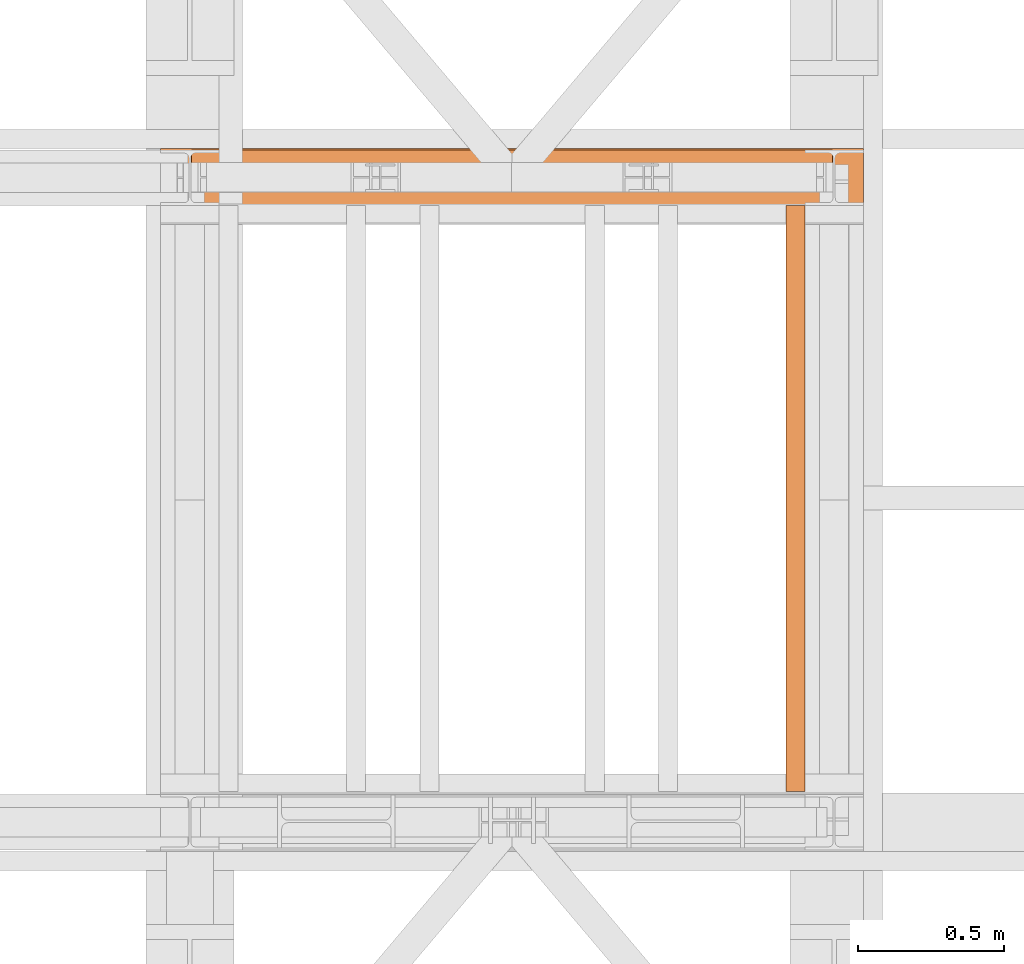
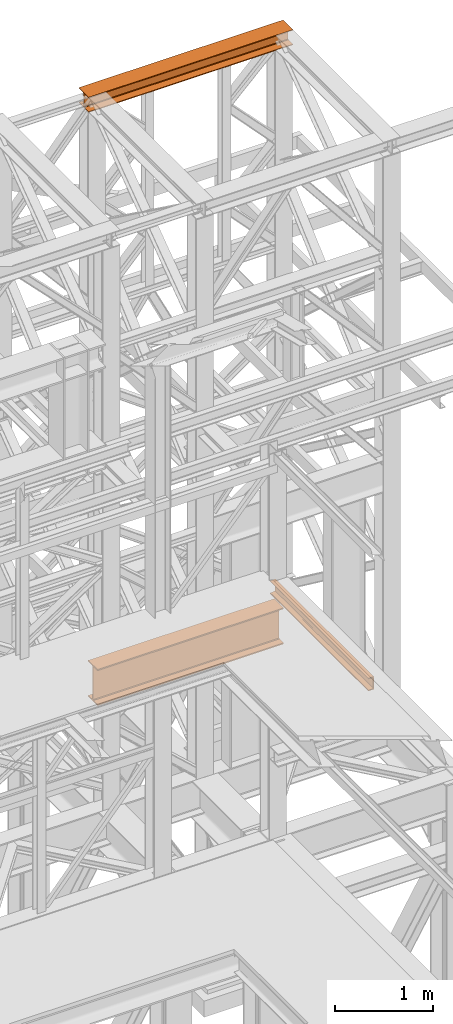
# One storey, part 186 of 208: 3 proxies.
"""IFC2X3 building model written with IfcOpenShell, lengths in millimetres."""

from ifc_helpers import new_model, entity, si_unit, converted_unit, frame, origin, origin_with_axes, place, context, subcontext, project, spatial, faceted_brep, element, save


model = new_model("IFC2X3")

# Units and contexts
model_context = context("Model", 3, precision=1e-05, world=origin())
plan_context = context("Plan", 3, precision=1e-05, world=origin())
body_context = subcontext(model_context, "Body", "Model", "MODEL_VIEW")
ifc_project = project(units=[si_unit("LENGTHUNIT", "METRE", prefix="MILLI"), converted_unit("PLANEANGLEUNIT", "DEGREE", entity("IfcPlaneAngleMeasure", 0.0174532925199433), si_unit("PLANEANGLEUNIT", "RADIAN"), dimensions=[0, 0, 0, 0, 0, 0, 0]), si_unit("AREAUNIT", "SQUARE_METRE"), si_unit("VOLUMEUNIT", "CUBIC_METRE")], contexts=[model_context, plan_context])

# Building, storey
building_placement = place(None, origin())
building = spatial("IfcBuilding", under=ifc_project, at=building_placement, CompositionType="COMPLEX")
storey_placement = place(building_placement, origin_with_axes())
storey = spatial("IfcBuildingStorey", under=building, at=storey_placement, Name="Geschoss", CompositionType="ELEMENT")

# Proxies
proxy_1_placement = place(storey_placement, frame((6599.254968580832, -13857.57439657637, 4834.989987483023), z_axis=(0.0, 0.0, 1.0), x_axis=(1.0, 0.0, 0.0)))
element("IfcBuildingElementProxy", 1, at=proxy_1_placement, inside=storey, context=body_context, shape_type="Brep", body=[
    faceted_brep([(2188.009999895692, 0.01000000000021828, 450.0100178813937), (2188.009999895692, 190.0100125169756, 450.0100178813937), (2188.009999895692, 190.0100125169756, 435.4100240564349), (2188.009999895692, 120.7100073045494, 435.4100091552737), (2188.009999895692, 109.841562265754, 433.2347078418734), (2188.009999895692, 101.8853126263621, 425.2784563398363), (2188.009999895692, 99.71000619068764, 414.4100113010409), (2188.009999895692, 99.71000619068764, 35.60999167919181), (2188.009999895692, 101.8853126263621, 24.74154664039634), (2188.009999895692, 109.841562265754, 16.78529513835929), (2188.009999895692, 120.7100073045494, 14.60999382495902), (2188.009999895692, 190.0100125169756, 14.60999382495902), (2188.009999895692, 190.0100125169756, 0.01000000000021828), (2188.009999895692, 0.01000000000021828, 0.01000000000021828), (2188.009999895692, 0.01000000000021828, 14.60999382495902), (2188.009999895692, 69.3100052124264, 14.60999382495902), (2188.009999895692, 80.17845025122188, 16.78529513835929), (2188.009999895692, 88.13469989061377, 24.74154664039634), (2188.009999895692, 90.3100063262882, 35.60999167919181), (2188.009999895692, 90.3100063262882, 414.4100113010409), (2188.009999895692, 88.13469989061377, 425.2784563398363), (2188.009999895692, 80.17845025122188, 433.2347078418734), (2188.009999895692, 69.3100052124264, 435.4100091552737), (2188.009999895692, 0.01000000000021828, 435.4100240564349), (2188.009999895692, 190.0100125169756, 450.0100178813937), (2188.009999895692, 0.01000000000021828, 450.0100178813937), (0.01000000000021828, 0.01000000000021828, 450.0100178813937), (0.01000000000021828, 190.0100125169756, 450.0100178813937), (2188.009999895692, 190.0100125169756, 435.4100240564349), (2188.009999895692, 190.0100125169756, 450.0100178813937), (0.01000000000021828, 190.0100125169756, 450.0100178813937), (0.01000000000021828, 190.0100125169756, 435.4100240564349), (2188.009999895692, 120.7100073045494, 435.4100091552737), (2188.009999895692, 190.0100125169756, 435.4100240564349), (0.01000000000021828, 190.0100125169756, 435.4100240564349), (0.01000000000021828, 120.7100073045494, 435.4100091552737), (2188.009999895692, 109.841562265754, 433.2347078418734), (2188.009999895692, 120.7100073045494, 435.4100091552737), (0.01000000000021828, 120.7100073045494, 435.4100091552737), (0.01000000000021828, 109.841562265754, 433.2347078418734), (2188.009999895692, 101.8853126263621, 425.2784563398363), (2188.009999895692, 109.841562265754, 433.2347078418734), (0.01000000000021828, 109.841562265754, 433.2347078418734), (0.01000000000021828, 101.8853126263621, 425.2784563398363), (2188.009999895692, 99.71000619068764, 414.4100113010409), (2188.009999895692, 101.8853126263621, 425.2784563398363), (0.01000000000021828, 101.8853126263621, 425.2784563398363), (0.01000000000021828, 99.71000619068764, 414.4100113010409), (2188.009999895692, 99.71000619068764, 35.60999167919181), (2188.009999895692, 99.71000619068764, 414.4100113010409), (0.01000000000021828, 99.71000619068764, 414.4100113010409), (0.01000000000021828, 99.71000619068764, 35.60999167919181), (2188.009999895692, 101.8853126263621, 24.74154664039634), (2188.009999895692, 99.71000619068764, 35.60999167919181), (0.01000000000021828, 99.71000619068764, 35.60999167919181), (0.01000000000021828, 101.8853126263621, 24.74154664039634), (2188.009999895692, 109.841562265754, 16.78529513835929), (2188.009999895692, 101.8853126263621, 24.74154664039634), (0.01000000000021828, 101.8853126263621, 24.74154664039634), (0.01000000000021828, 109.841562265754, 16.78529513835929), (2188.009999895692, 120.7100073045494, 14.60999382495902), (2188.009999895692, 109.841562265754, 16.78529513835929), (0.01000000000021828, 109.841562265754, 16.78529513835929), (0.01000000000021828, 120.7100073045494, 14.60999382495902), (2188.009999895692, 190.0100125169756, 14.60999382495902), (2188.009999895692, 120.7100073045494, 14.60999382495902), (0.01000000000021828, 120.7100073045494, 14.60999382495902), (0.01000000000021828, 190.0100125169756, 14.60999382495902), (2188.009999895692, 190.0100125169756, 0.01000000000021828), (2188.009999895692, 190.0100125169756, 14.60999382495902), (0.01000000000021828, 190.0100125169756, 14.60999382495902), (0.01000000000021828, 190.0100125169756, 0.01000000000021828), (2188.009999895692, 0.01000000000021828, 0.01000000000021828), (2188.009999895692, 190.0100125169756, 0.01000000000021828), (0.01000000000021828, 190.0100125169756, 0.01000000000021828), (0.01000000000021828, 0.01000000000021828, 0.01000000000021828), (2188.009999895692, 0.01000000000021828, 14.60999382495902), (2188.009999895692, 0.01000000000021828, 0.01000000000021828), (0.01000000000021828, 0.01000000000021828, 0.01000000000021828), (0.01000000000021828, 0.01000000000021828, 14.60999382495902), (2188.009999895692, 69.3100052124264, 14.60999382495902), (2188.009999895692, 0.01000000000021828, 14.60999382495902), (0.01000000000021828, 0.01000000000021828, 14.60999382495902), (0.01000000000021828, 69.3100052124264, 14.60999382495902), (2188.009999895692, 80.17845025122188, 16.78529513835929), (2188.009999895692, 69.3100052124264, 14.60999382495902), (0.01000000000021828, 69.3100052124264, 14.60999382495902), (0.01000000000021828, 80.17845025122188, 16.78529513835929), (2188.009999895692, 88.13469989061377, 24.74154664039634), (2188.009999895692, 80.17845025122188, 16.78529513835929), (0.01000000000021828, 80.17845025122188, 16.78529513835929), (0.01000000000021828, 88.13469989061377, 24.74154664039634), (2188.009999895692, 90.3100063262882, 35.60999167919181), (2188.009999895692, 88.13469989061377, 24.74154664039634), (0.01000000000021828, 88.13469989061377, 24.74154664039634), (0.01000000000021828, 90.3100063262882, 35.60999167919181), (2188.009999895692, 90.3100063262882, 414.4100113010409), (2188.009999895692, 90.3100063262882, 35.60999167919181), (0.01000000000021828, 90.3100063262882, 35.60999167919181), (0.01000000000021828, 90.3100063262882, 414.4100113010409), (2188.009999895692, 88.13469989061377, 425.2784563398363), (2188.009999895692, 90.3100063262882, 414.4100113010409), (0.01000000000021828, 90.3100063262882, 414.4100113010409), (0.01000000000021828, 88.13469989061377, 425.2784563398363), (2188.009999895692, 80.17845025122188, 433.2347078418734), (2188.009999895692, 88.13469989061377, 425.2784563398363), (0.01000000000021828, 88.13469989061377, 425.2784563398363), (0.01000000000021828, 80.17845025122188, 433.2347078418734), (2188.009999895692, 69.3100052124264, 435.4100091552737), (2188.009999895692, 80.17845025122188, 433.2347078418734), (0.01000000000021828, 80.17845025122188, 433.2347078418734), (0.01000000000021828, 69.3100052124264, 435.4100091552737), (2188.009999895692, 0.01000000000021828, 435.4100240564349), (2188.009999895692, 69.3100052124264, 435.4100091552737), (0.01000000000021828, 69.3100052124264, 435.4100091552737), (0.01000000000021828, 0.01000000000021828, 435.4100240564349), (2188.009999895692, 0.01000000000021828, 450.0100178813937), (2188.009999895692, 0.01000000000021828, 435.4100240564349), (0.01000000000021828, 0.01000000000021828, 435.4100240564349), (0.01000000000021828, 0.01000000000021828, 450.0100178813937), (0.01000000000021828, 0.01000000000021828, 450.0100178813937), (0.01000000000021828, 0.01000000000021828, 435.4100240564349), (0.01000000000021828, 69.3100052124264, 435.4100091552737), (0.01000000000021828, 80.17845025122188, 433.2347078418734), (0.01000000000021828, 88.13469989061377, 425.2784563398363), (0.01000000000021828, 90.3100063262882, 414.4100113010409), (0.01000000000021828, 90.3100063262882, 35.60999167919181), (0.01000000000021828, 88.13469989061377, 24.74154664039634), (0.01000000000021828, 80.17845025122188, 16.78529513835929), (0.01000000000021828, 69.3100052124264, 14.60999382495902), (0.01000000000021828, 0.01000000000021828, 14.60999382495902), (0.01000000000021828, 0.01000000000021828, 0.01000000000021828), (0.01000000000021828, 190.0100125169756, 0.01000000000021828), (0.01000000000021828, 190.0100125169756, 14.60999382495902), (0.01000000000021828, 120.7100073045494, 14.60999382495902), (0.01000000000021828, 109.841562265754, 16.78529513835929), (0.01000000000021828, 101.8853126263621, 24.74154664039634), (0.01000000000021828, 99.71000619068764, 35.60999167919181), (0.01000000000021828, 99.71000619068764, 414.4100113010409), (0.01000000000021828, 101.8853126263621, 425.2784563398363), (0.01000000000021828, 109.841562265754, 433.2347078418734), (0.01000000000021828, 120.7100073045494, 435.4100091552737), (0.01000000000021828, 190.0100125169756, 435.4100240564349), (0.01000000000021828, 190.0100125169756, 450.0100178813937)], [[[0, 1, 2, 3, 4, 5, 6, 7, 8, 9, 10, 11, 12, 13, 14, 15, 16, 17, 18, 19, 20, 21, 22, 23]], [[24, 25, 26, 27]], [[28, 29, 30, 31]], [[32, 33, 34, 35]], [[36, 37, 38, 39]], [[40, 41, 42, 43]], [[44, 45, 46, 47]], [[48, 49, 50, 51]], [[52, 53, 54, 55]], [[56, 57, 58, 59]], [[60, 61, 62, 63]], [[64, 65, 66, 67]], [[68, 69, 70, 71]], [[72, 73, 74, 75]], [[76, 77, 78, 79]], [[80, 81, 82, 83]], [[84, 85, 86, 87]], [[88, 89, 90, 91]], [[92, 93, 94, 95]], [[96, 97, 98, 99]], [[100, 101, 102, 103]], [[104, 105, 106, 107]], [[108, 109, 110, 111]], [[112, 113, 114, 115]], [[116, 117, 118, 119]], [[120, 121, 122, 123, 124, 125, 126, 127, 128, 129, 130, 131, 132, 133, 134, 135, 136, 137, 138, 139, 140, 141, 142, 143]]], orient=[[False], [False], [False], [False], [False], [False], [False], [False], [False], [False], [False], [False], [False], [False], [False], [False], [False], [False], [False], [False], [False], [False], [False], [False], [False], [False]]),
])
proxy_2_placement = place(storey_placement, frame((6493.254967038551, -13862.574391808, 12249.99005869381), z_axis=(0.0, 0.0, 1.0), x_axis=(1.0, 0.0, 0.0)))
element("IfcBuildingElementProxy", 2, at=proxy_2_placement, inside=storey, context=body_context, shape_type="Brep", body=[
    faceted_brep([(0.009999999999308784, 0.01000000000021828, 0.01000000000021828), (0.009999999999308784, 200.0100029802325, 0.01000000000021828), (0.009999999999308784, 200.0100029802325, 10.00999791383765), (0.009999999999308784, 121.2600035762789, 10.01000536441825), (0.009999999999308784, 111.9441915473344, 11.87455041170142), (0.009999999999308784, 105.1245498640838, 18.69419349193595), (0.009999999999308784, 103.2600015571716, 28.01000458955787), (0.009999999999308784, 103.2600015571716, 162.0100153779986), (0.009999999999308784, 105.1245498640838, 171.3258264756205), (0.009999999999308784, 111.9441915473344, 178.145469555855), (0.009999999999308784, 121.2600035762789, 180.0100146031382), (0.009999999999308784, 200.0100029802325, 180.0100146031382), (0.009999999999308784, 200.0100029802325, 190.0100125169756), (0.009999999999308784, 0.01000000000021828, 190.0100125169756), (0.009999999999308784, 0.01000000000021828, 180.0100146031382), (0.009999999999308784, 78.75999940395377, 180.0100146031382), (0.009999999999308784, 88.07581143289826, 178.145469555855), (0.009999999999308784, 94.89545311614893, 171.3258264756205), (0.009999999999308784, 96.76000142306111, 162.0100153779986), (0.009999999999308784, 96.76000142306111, 28.01000458955787), (0.009999999999308784, 94.89545311614893, 18.69419349193595), (0.009999999999308784, 88.07581143289826, 11.87455041170142), (0.009999999999308784, 78.75999940395377, 10.01000536441825), (0.009999999999308784, 0.01000000000021828, 10.00999791383765), (0.009999999999308784, 200.0100029802325, 0.01000000000021828), (0.009999999999308784, 0.01000000000021828, 0.01000000000021828), (2400.010002980233, 0.01000000000021828, 0.01000000000021828), (2400.010002980233, 200.0100029802325, 0.01000000000021828), (0.009999999999308784, 200.0100029802325, 10.00999791383765), (0.009999999999308784, 200.0100029802325, 0.01000000000021828), (2400.010002980233, 200.0100029802325, 0.01000000000021828), (2400.010002980233, 200.0100029802325, 10.00999791383765), (0.009999999999308784, 121.2600035762789, 10.01000536441825), (0.009999999999308784, 200.0100029802325, 10.00999791383765), (2400.010002980233, 200.0100029802325, 10.00999791383765), (2400.010002980233, 121.2600035762789, 10.01000536441825), (0.009999999999308784, 111.9441915473344, 11.87455041170142), (0.009999999999308784, 121.2600035762789, 10.01000536441825), (2400.010002980233, 121.2600035762789, 10.01000536441825), (2400.010002980233, 111.9441915473344, 11.87455041170142), (0.009999999999308784, 105.1245498640838, 18.69419349193595), (0.009999999999308784, 111.9441915473344, 11.87455041170142), (2400.010002980233, 111.9441915473344, 11.87455041170142), (2400.010002980233, 105.1245498640838, 18.69419349193595), (0.009999999999308784, 103.2600015571716, 28.01000458955787), (0.009999999999308784, 105.1245498640838, 18.69419349193595), (2400.010002980233, 105.1245498640838, 18.69419349193595), (2400.010002980233, 103.2600015571716, 28.01000458955787), (0.009999999999308784, 103.2600015571716, 162.0100153779986), (0.009999999999308784, 103.2600015571716, 28.01000458955787), (2400.010002980233, 103.2600015571716, 28.01000458955787), (2400.010002980233, 103.2600015571716, 162.0100153779986), (0.009999999999308784, 105.1245498640838, 171.3258264756205), (0.009999999999308784, 103.2600015571716, 162.0100153779986), (2400.010002980233, 103.2600015571716, 162.0100153779986), (2400.010002980233, 105.1245498640838, 171.3258264756205), (0.009999999999308784, 111.9441915473344, 178.145469555855), (0.009999999999308784, 105.1245498640838, 171.3258264756205), (2400.010002980233, 105.1245498640838, 171.3258264756205), (2400.010002980233, 111.9441915473344, 178.145469555855), (0.009999999999308784, 121.2600035762789, 180.0100146031382), (0.009999999999308784, 111.9441915473344, 178.145469555855), (2400.010002980233, 111.9441915473344, 178.145469555855), (2400.010002980233, 121.2600035762789, 180.0100146031382), (0.009999999999308784, 200.0100029802325, 180.0100146031382), (0.009999999999308784, 121.2600035762789, 180.0100146031382), (2400.010002980233, 121.2600035762789, 180.0100146031382), (2400.010002980233, 200.0100029802325, 180.0100146031382), (0.009999999999308784, 200.0100029802325, 190.0100125169756), (0.009999999999308784, 200.0100029802325, 180.0100146031382), (2400.010002980233, 200.0100029802325, 180.0100146031382), (2400.010002980233, 200.0100029802325, 190.0100125169756), (0.009999999999308784, 0.01000000000021828, 190.0100125169756), (0.009999999999308784, 200.0100029802325, 190.0100125169756), (2400.010002980233, 200.0100029802325, 190.0100125169756), (2400.010002980233, 0.01000000000021828, 190.0100125169756), (0.009999999999308784, 0.01000000000021828, 180.0100146031382), (0.009999999999308784, 0.01000000000021828, 190.0100125169756), (2400.010002980233, 0.01000000000021828, 190.0100125169756), (2400.010002980233, 0.01000000000021828, 180.0100146031382), (0.009999999999308784, 78.75999940395377, 180.0100146031382), (0.009999999999308784, 0.01000000000021828, 180.0100146031382), (2400.010002980233, 0.01000000000021828, 180.0100146031382), (2400.010002980233, 78.75999940395377, 180.0100146031382), (0.009999999999308784, 88.07581143289826, 178.145469555855), (0.009999999999308784, 78.75999940395377, 180.0100146031382), (2400.010002980233, 78.75999940395377, 180.0100146031382), (2400.010002980233, 88.07581143289826, 178.145469555855), (0.009999999999308784, 94.89545311614893, 171.3258264756205), (0.009999999999308784, 88.07581143289826, 178.145469555855), (2400.010002980233, 88.07581143289826, 178.145469555855), (2400.010002980233, 94.89545311614893, 171.3258264756205), (0.009999999999308784, 96.76000142306111, 162.0100153779986), (0.009999999999308784, 94.89545311614893, 171.3258264756205), (2400.010002980233, 94.89545311614893, 171.3258264756205), (2400.010002980233, 96.76000142306111, 162.0100153779986), (0.009999999999308784, 96.76000142306111, 28.01000458955787), (0.009999999999308784, 96.76000142306111, 162.0100153779986), (2400.010002980233, 96.76000142306111, 162.0100153779986), (2400.010002980233, 96.76000142306111, 28.01000458955787), (0.009999999999308784, 94.89545311614893, 18.69419349193595), (0.009999999999308784, 96.76000142306111, 28.01000458955787), (2400.010002980233, 96.76000142306111, 28.01000458955787), (2400.010002980233, 94.89545311614893, 18.69419349193595), (0.009999999999308784, 88.07581143289826, 11.87455041170142), (0.009999999999308784, 94.89545311614893, 18.69419349193595), (2400.010002980233, 94.89545311614893, 18.69419349193595), (2400.010002980233, 88.07581143289826, 11.87455041170142), (0.009999999999308784, 78.75999940395377, 10.01000536441825), (0.009999999999308784, 88.07581143289826, 11.87455041170142), (2400.010002980233, 88.07581143289826, 11.87455041170142), (2400.010002980233, 78.75999940395377, 10.01000536441825), (0.009999999999308784, 0.01000000000021828, 10.00999791383765), (0.009999999999308784, 78.75999940395377, 10.01000536441825), (2400.010002980233, 78.75999940395377, 10.01000536441825), (2400.010002980233, 0.01000000000021828, 10.00999791383765), (0.009999999999308784, 0.01000000000021828, 0.01000000000021828), (0.009999999999308784, 0.01000000000021828, 10.00999791383765), (2400.010002980233, 0.01000000000021828, 10.00999791383765), (2400.010002980233, 0.01000000000021828, 0.01000000000021828), (2400.010002980233, 0.01000000000021828, 0.01000000000021828), (2400.010002980233, 0.01000000000021828, 10.00999791383765), (2400.010002980233, 78.75999940395377, 10.01000536441825), (2400.010002980233, 88.07581143289826, 11.87455041170142), (2400.010002980233, 94.89545311614893, 18.69419349193595), (2400.010002980233, 96.76000142306111, 28.01000458955787), (2400.010002980233, 96.76000142306111, 162.0100153779986), (2400.010002980233, 94.89545311614893, 171.3258264756205), (2400.010002980233, 88.07581143289826, 178.145469555855), (2400.010002980233, 78.75999940395377, 180.0100146031382), (2400.010002980233, 0.01000000000021828, 180.0100146031382), (2400.010002980233, 0.01000000000021828, 190.0100125169756), (2400.010002980233, 200.0100029802325, 190.0100125169756), (2400.010002980233, 200.0100029802325, 180.0100146031382), (2400.010002980233, 121.2600035762789, 180.0100146031382), (2400.010002980233, 111.9441915473344, 178.145469555855), (2400.010002980233, 105.1245498640838, 171.3258264756205), (2400.010002980233, 103.2600015571716, 162.0100153779986), (2400.010002980233, 103.2600015571716, 28.01000458955787), (2400.010002980233, 105.1245498640838, 18.69419349193595), (2400.010002980233, 111.9441915473344, 11.87455041170142), (2400.010002980233, 121.2600035762789, 10.01000536441825), (2400.010002980233, 200.0100029802325, 10.00999791383765), (2400.010002980233, 200.0100029802325, 0.01000000000021828)], [[[0, 1, 2, 3, 4, 5, 6, 7, 8, 9, 10, 11, 12, 13, 14, 15, 16, 17, 18, 19, 20, 21, 22, 23]], [[24, 25, 26, 27]], [[28, 29, 30, 31]], [[32, 33, 34, 35]], [[36, 37, 38, 39]], [[40, 41, 42, 43]], [[44, 45, 46, 47]], [[48, 49, 50, 51]], [[52, 53, 54, 55]], [[56, 57, 58, 59]], [[60, 61, 62, 63]], [[64, 65, 66, 67]], [[68, 69, 70, 71]], [[72, 73, 74, 75]], [[76, 77, 78, 79]], [[80, 81, 82, 83]], [[84, 85, 86, 87]], [[88, 89, 90, 91]], [[92, 93, 94, 95]], [[96, 97, 98, 99]], [[100, 101, 102, 103]], [[104, 105, 106, 107]], [[108, 109, 110, 111]], [[112, 113, 114, 115]], [[116, 117, 118, 119]], [[120, 121, 122, 123, 124, 125, 126, 127, 128, 129, 130, 131, 132, 133, 134, 135, 136, 137, 138, 139, 140, 141, 142, 143]]], orient=[[False], [False], [False], [False], [False], [False], [False], [False], [False], [False], [False], [False], [False], [False], [False], [False], [False], [False], [False], [False], [False], [False], [False], [False], [False], [False]]),
])
proxy_3_placement = place(storey_placement, frame((8628.25496703855, -15857.57439274273, 5518.360005364418), z_axis=(0.0, 0.0, 1.0), x_axis=(1.0, 0.0, 0.0)))
element("IfcBuildingElementProxy", 3, at=proxy_3_placement, inside=storey, context=body_context, shape_type="Brep", body=[
    faceted_brep([(65.01000000000022, 2000.009997019768, 160.0100000000002), (65.01000000000204, 0.01000000000021828, 160.0100000000002), (0.01000000000203727, 0.01000000000021828, 160.0100000000002), (0.01000000000021828, 2000.009997019768, 160.0100000000002), (0.01000000000021828, 2000.009997019768, 160.0100000000002), (0.01000000000203727, 0.01000000000021828, 160.0100000000002), (0.01000000000203727, 0.01000000000021828, 156.8875719297539), (0.01000000000021828, 2000.009997019768, 156.8875719297539), (0.01000000000021828, 2000.009997019768, 156.8875719297539), (0.01000000000203727, 0.01000000000021828, 156.8875719297539), (0.2527365771748009, 0.01000000000021828, 155.2717110918293), (0.2527365771729819, 2000.009997019768, 155.2717110918293), (0.2527365771729819, 2000.009997019768, 155.2717110918293), (0.2527365771748009, 0.01000000000021828, 155.2717110918293), (0.9594677141431021, 0.01000000000021828, 153.7984655565542), (0.959467714144921, 2000.009997019768, 153.7984655565542), (0.959467714144921, 2000.009997019768, 153.7984655565542), (0.9594677141431021, 0.01000000000021828, 153.7984655565542), (2.067848361533834, 0.01000000000021828, 152.5978732961266), (2.067848361532015, 2000.009997019768, 152.5978732961266), (2.067848361532015, 2000.009997019768, 152.5978732961266), (2.067848361533834, 0.01000000000021828, 152.5978732961266), (3.480043588519038, 0.01000000000021828, 151.7759086082897), (3.480043588517219, 2000.009997019768, 151.7759086082897), (3.480043588517219, 2000.009997019768, 151.7759086082897), (3.480043588519038, 0.01000000000021828, 151.7759086082897), (5.071401277447876, 0.01000000000021828, 151.4050878978051), (5.071401277446057, 2000.009997019768, 151.4050878978051), (5.071401277446057, 2000.009997019768, 151.4050878978051), (5.071401277447876, 0.01000000000021828, 151.4050878978051), (47.84732483397238, 0.01000000000021828, 147.9830140132835), (47.84732483397056, 2000.009997019768, 147.9830140132835), (47.84732483397056, 2000.009997019768, 147.9830140132835), (47.84732483397238, 0.01000000000021828, 147.9830140132835), (50.81159179199312, 0.01000000000021828, 147.318026761528), (50.8115917919913, 2000.009997019768, 147.318026761528), (50.8115917919913, 2000.009997019768, 147.318026761528), (50.81159179199312, 0.01000000000021828, 147.318026761528), (53.58138040071208, 0.01000000000021828, 145.7058782528511), (53.5813804007139, 2000.009997019768, 145.7058782528511), (53.5813804007139, 2000.009997019768, 145.7058782528511), (53.58138040071208, 0.01000000000021828, 145.7058782528511), (55.69737981845537, 0.01000000000021828, 143.4138384829421), (55.69737981845356, 2000.009997019768, 143.4138384829421), (55.69737981845356, 2000.009997019768, 143.4138384829421), (55.69737981845537, 0.01000000000021828, 143.4138384829421), (57.04659380721569, 0.01000000000021828, 140.6012788246917), (57.04659380721387, 2000.009997019768, 140.6012788246917), (57.04659380721387, 2000.009997019768, 140.6012788246917), (57.04659380721569, 0.01000000000021828, 140.6012788246917), (57.51000000000204, 0.01000000000021828, 137.5164535886543), (57.51000000000022, 2000.009997019768, 137.5164535886543), (57.51000000000022, 2000.009997019768, 137.5164535886543), (57.51000000000204, 0.01000000000021828, 137.5164535886543), (57.51000000000204, 0.01000000000021828, 22.503546411348), (57.51000000000022, 2000.009997019768, 22.503546411348), (57.51000000000022, 2000.009997019768, 22.503546411348), (57.51000000000204, 0.01000000000021828, 22.503546411348), (57.04659380721569, 0.01000000000021828, 19.41872117530875), (57.04659380721387, 2000.009997019768, 19.41872117530875), (57.04659380721387, 2000.009997019768, 19.41872117530875), (57.04659380721569, 0.01000000000021828, 19.41872117530875), (55.69737981845537, 0.01000000000021828, 16.60616151705835), (55.69737981845356, 2000.009997019768, 16.60616151705835), (55.69737981845356, 2000.009997019768, 16.60616151705835), (55.69737981845537, 0.01000000000021828, 16.60616151705835), (53.58138040071208, 0.01000000000021828, 14.31412174714933), (53.5813804007139, 2000.009997019768, 14.31412174714933), (53.5813804007139, 2000.009997019768, 14.31412174714933), (53.58138040071208, 0.01000000000021828, 14.31412174714933), (50.88537133101636, 0.01000000000021828, 12.74491643400688), (50.88537133101818, 2000.009997019768, 12.74491643400688), (50.88537133101818, 2000.009997019768, 12.74491643400688), (50.88537133101636, 0.01000000000021828, 12.74491643400688), (47.84732483397238, 0.01000000000021828, 12.03698598671872), (47.84732483397056, 2000.009997019768, 12.03698598671872), (47.84732483397056, 2000.009997019768, 12.03698598671872), (47.84732483397238, 0.01000000000021828, 12.03698598671872), (5.071401277447876, 0.01000000000021828, 8.614912102195376), (5.071401277446057, 2000.009997019768, 8.614912102195376), (5.071401277446057, 2000.009997019768, 8.614912102195376), (5.071401277447876, 0.01000000000021828, 8.614912102195376), (3.480043588519038, 0.01000000000021828, 8.244091391710754), (3.480043588517219, 2000.009997019768, 8.244091391710754), (3.480043588517219, 2000.009997019768, 8.244091391710754), (3.480043588519038, 0.01000000000021828, 8.244091391710754), (2.067848361533834, 0.01000000000021828, 7.422126703873801), (2.067848361532015, 2000.009997019768, 7.422126703873801), (2.067848361532015, 2000.009997019768, 7.422126703873801), (2.067848361533834, 0.01000000000021828, 7.422126703873801), (0.9594677141431021, 0.01000000000021828, 6.221534443446217), (0.959467714144921, 2000.009997019768, 6.221534443446217), (0.959467714144921, 2000.009997019768, 6.221534443446217), (0.9594677141431021, 0.01000000000021828, 6.221534443446217), (0.2527365771748009, 0.01000000000021828, 4.748288908172981), (0.2527365771729819, 2000.009997019768, 4.748288908172981), (0.2527365771729819, 2000.009997019768, 4.748288908172981), (0.2527365771748009, 0.01000000000021828, 4.748288908172981), (0.01000000000203727, 0.01000000000021828, 0.01000000000021828), (0.01000000000021828, 2000.009997019768, 0.01000000000021828), (0.01000000000021828, 2000.009997019768, 0.01000000000021828), (0.01000000000203727, 0.01000000000021828, 0.01000000000021828), (65.01000000000204, 0.01000000000021828, 0.01000000000021828), (65.01000000000022, 2000.009997019768, 0.01000000000021828), (65.01000000000022, 2000.009997019768, 0.01000000000021828), (65.01000000000204, 0.01000000000021828, 0.01000000000021828), (65.01000000000204, 0.01000000000021828, 160.0100000000002), (65.01000000000022, 2000.009997019768, 160.0100000000002), (65.01000000000022, 2000.009997019768, 160.0100000000002), (0.01000000000021828, 2000.009997019768, 160.0100000000002), (0.01000000000021828, 2000.009997019768, 156.8875719297539), (0.2527365771729819, 2000.009997019768, 155.2717110918293), (0.959467714144921, 2000.009997019768, 153.7984655565542), (2.067848361532015, 2000.009997019768, 152.5978732961266), (3.480043588517219, 2000.009997019768, 151.7759086082897), (5.071401277446057, 2000.009997019768, 151.4050878978051), (47.84732483397056, 2000.009997019768, 147.9830140132835), (50.8115917919913, 2000.009997019768, 147.318026761528), (53.5813804007139, 2000.009997019768, 145.7058782528511), (55.69737981845356, 2000.009997019768, 143.4138384829421), (57.04659380721387, 2000.009997019768, 140.6012788246917), (57.51000000000022, 2000.009997019768, 137.5164535886543), (57.51000000000022, 2000.009997019768, 22.503546411348), (57.04659380721387, 2000.009997019768, 19.41872117530875), (55.69737981845356, 2000.009997019768, 16.60616151705835), (53.5813804007139, 2000.009997019768, 14.31412174714933), (50.88537133101818, 2000.009997019768, 12.74491643400688), (47.84732483397056, 2000.009997019768, 12.03698598671872), (5.071401277446057, 2000.009997019768, 8.614912102195376), (3.480043588517219, 2000.009997019768, 8.244091391710754), (2.067848361532015, 2000.009997019768, 7.422126703873801), (0.959467714144921, 2000.009997019768, 6.221534443446217), (0.2527365771729819, 2000.009997019768, 4.748288908172981), (0.01000000000021828, 2000.009997019768, 0.01000000000021828), (65.01000000000022, 2000.009997019768, 0.01000000000021828), (65.01000000000204, 0.01000000000021828, 160.0100000000002), (65.01000000000204, 0.01000000000021828, 0.01000000000021828), (0.01000000000203727, 0.01000000000021828, 0.01000000000021828), (0.2527365771748009, 0.01000000000021828, 4.748288908172981), (0.9594677141431021, 0.01000000000021828, 6.221534443446217), (2.067848361533834, 0.01000000000021828, 7.422126703873801), (3.480043588519038, 0.01000000000021828, 8.244091391710754), (5.071401277447876, 0.01000000000021828, 8.614912102195376), (47.84732483397238, 0.01000000000021828, 12.03698598671872), (50.88537133101636, 0.01000000000021828, 12.74491643400688), (53.58138040071208, 0.01000000000021828, 14.31412174714933), (55.69737981845537, 0.01000000000021828, 16.60616151705835), (57.04659380721569, 0.01000000000021828, 19.41872117530875), (57.51000000000204, 0.01000000000021828, 22.503546411348), (57.51000000000204, 0.01000000000021828, 137.5164535886543), (57.04659380721569, 0.01000000000021828, 140.6012788246917), (55.69737981845537, 0.01000000000021828, 143.4138384829421), (53.58138040071208, 0.01000000000021828, 145.7058782528511), (50.81159179199312, 0.01000000000021828, 147.318026761528), (47.84732483397238, 0.01000000000021828, 147.9830140132835), (5.071401277447876, 0.01000000000021828, 151.4050878978051), (3.480043588519038, 0.01000000000021828, 151.7759086082897), (2.067848361533834, 0.01000000000021828, 152.5978732961266), (0.9594677141431021, 0.01000000000021828, 153.7984655565542), (0.2527365771748009, 0.01000000000021828, 155.2717110918293), (0.01000000000203727, 0.01000000000021828, 156.8875719297539), (0.01000000000203727, 0.01000000000021828, 160.0100000000002)], [[[0, 1, 2, 3]], [[4, 5, 6, 7]], [[8, 9, 10, 11]], [[12, 13, 14, 15]], [[16, 17, 18, 19]], [[20, 21, 22, 23]], [[24, 25, 26, 27]], [[28, 29, 30, 31]], [[32, 33, 34, 35]], [[36, 37, 38, 39]], [[40, 41, 42, 43]], [[44, 45, 46, 47]], [[48, 49, 50, 51]], [[52, 53, 54, 55]], [[56, 57, 58, 59]], [[60, 61, 62, 63]], [[64, 65, 66, 67]], [[68, 69, 70, 71]], [[72, 73, 74, 75]], [[76, 77, 78, 79]], [[80, 81, 82, 83]], [[84, 85, 86, 87]], [[88, 89, 90, 91]], [[92, 93, 94, 95]], [[96, 97, 98, 99]], [[100, 101, 102, 103]], [[104, 105, 106, 107]], [[108, 109, 110, 111, 112, 113, 114, 115, 116, 117, 118, 119, 120, 121, 122, 123, 124, 125, 126, 127, 128, 129, 130, 131, 132, 133, 134]], [[135, 136, 137, 138, 139, 140, 141, 142, 143, 144, 145, 146, 147, 148, 149, 150, 151, 152, 153, 154, 155, 156, 157, 158, 159, 160, 161]]], orient=[[False], [False], [False], [False], [False], [False], [False], [False], [False], [False], [False], [False], [False], [False], [False], [False], [False], [False], [False], [False], [False], [False], [False], [False], [False], [False], [False], [False], [False]]),
])

save(model, "model.ifc")
